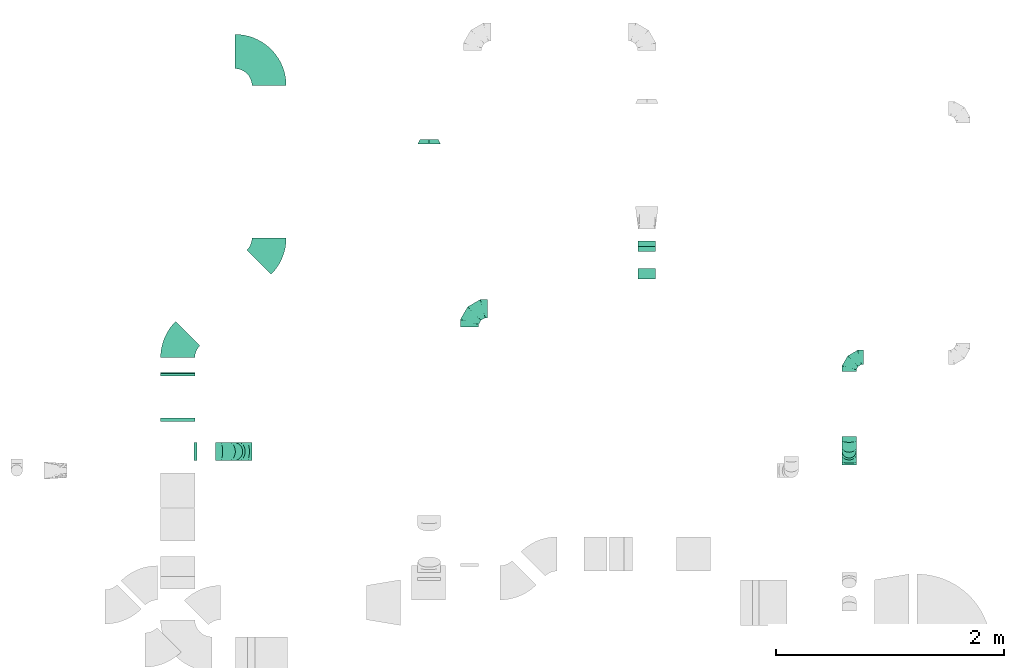
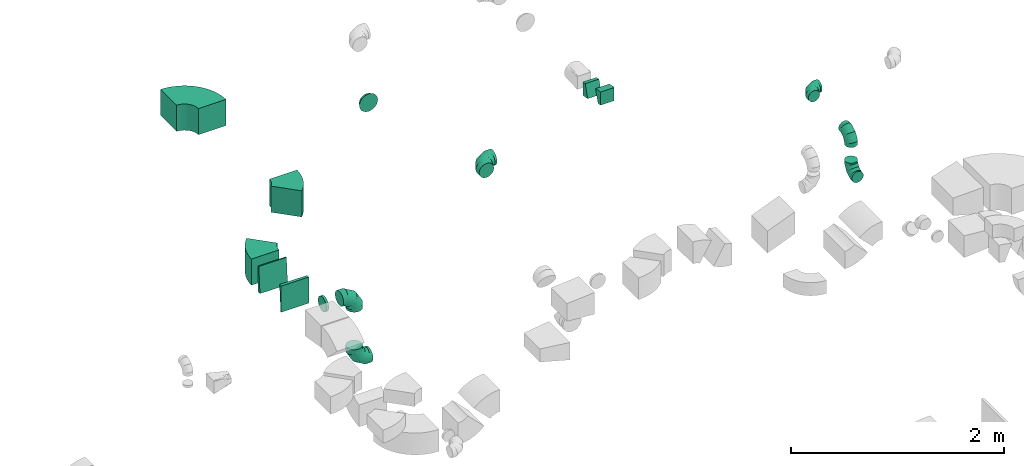
# One storey, part 33 of 44: 15 flow fittings.
"""IFC2X3 building model written with IfcOpenShell, lengths in millimetres."""

import ifcopenshell
import ifcopenshell.guid

model = None  # the IFC model being written
_history = None  # IfcOwnerHistory: only IFC2X3 demands one
_inside = {}  # id of a spatial element -> (the spatial element, [elements in it])
_under = {}  # id of a project, library or spatial element -> (it, [spatial elements below it])
_declared = {}  # id of a project -> (the project, [libraries it declares])
_typed = {}  # id of a type object -> (the type object, [elements of that type])
_made_of = {}  # id of a material, layer set ... -> (it, [elements and type objects made of it])


def new_model(schema):
    """Start an empty IFC model of exactly this schema.

    Asked for "IFC4X3", IfcOpenShell would pick the latest addendum, in which some entities
    have other attributes; the version numbers below select the first issue.
    IFC2X3 requires an IfcOwnerHistory on every rooted entity: one is made here for all.
    """
    global model, _history
    if schema == "IFC4X3":
        model = ifcopenshell.file(schema_version=(4, 3, 0, 0))
    else:
        model = ifcopenshell.file(schema=schema)
    _inside.clear()
    _under.clear()
    _declared.clear()
    _typed.clear()
    _made_of.clear()
    _history = None
    if model.schema == "IFC2X3":
        org = make("IfcOrganization", Name="unknown")
        user = make(
            "IfcPersonAndOrganization",
            ThePerson=make("IfcPerson", FamilyName="unknown"),
            TheOrganization=org,
        )
        app = make(
            "IfcApplication",
            ApplicationDeveloper=org,
            Version="unknown",
            ApplicationFullName="unknown",
            ApplicationIdentifier="unknown",
        )
        _history = make(
            "IfcOwnerHistory",
            OwningUser=user,
            OwningApplication=app,
            ChangeAction="ADDED",
            CreationDate=0,
        )
    return model


def make(cls, **values):
    """One entity of the class cls with the attributes given. An attribute that is None is left unset."""
    return model.create_entity(
        cls, **{name: value for name, value in values.items() if value is not None}
    )


def entity(cls, *values):
    """Any entity or typed value of the class cls, its attributes in the order of the schema. None: left unset."""
    e = model.create_entity(cls)
    for i, value in enumerate(values):
        if value is not None:
            e[i] = value
    return e


def rooted(cls, **values):
    """An entity with a GlobalId (a new one), such as an element, a storey or a relation."""
    return make(cls, GlobalId=ifcopenshell.guid.new(), OwnerHistory=_history, **values)


def si_unit(unit_type, name, prefix=None):
    """IfcSIUnit, for example si_unit("LENGTHUNIT", "METRE", prefix="MILLI")."""
    return make("IfcSIUnit", UnitType=unit_type, Prefix=prefix, Name=name)


def converted_unit(unit_type, name, factor, base, dimensions=None, offset=None):
    """IfcConversionBasedUnit, such as the inch: factor (a typed value) times the base unit."""
    return make(
        "IfcConversionBasedUnit"
        if offset is None
        else "IfcConversionBasedUnitWithOffset",
        ConversionOffset=offset,
        Dimensions=None
        if dimensions is None
        else entity("IfcDimensionalExponents", *dimensions),
        UnitType=unit_type,
        Name=name,
        ConversionFactor=make(
            "IfcMeasureWithUnit", ValueComponent=factor, UnitComponent=base
        ),
    )


def derived_unit(unit_type, elements):
    """IfcDerivedUnit: a product of units, each with its exponent."""
    return make(
        "IfcDerivedUnit",
        Elements=[
            make("IfcDerivedUnitElement", Unit=unit, Exponent=power)
            for unit, power in elements
        ],
        UnitType=unit_type,
    )


def assignment(units):
    """IfcUnitAssignment: the units of a project."""
    return None if units is None else make("IfcUnitAssignment", Units=units)


def point(xyz):
    """IfcCartesianPoint."""
    return None if xyz is None else make("IfcCartesianPoint", Coordinates=xyz)


def direction(xyz):
    """IfcDirection."""
    return None if xyz is None else make("IfcDirection", DirectionRatios=xyz)


def frame(location, z_axis=None, x_axis=None):
    """IfcAxis2Placement3D, a coordinate frame: its origin and axes. An axis left out is left unset."""
    return make(
        "IfcAxis2Placement3D",
        Location=point(location),
        Axis=direction(z_axis),
        RefDirection=direction(x_axis),
    )


def frame_2d(location, x_axis=None):
    """IfcAxis2Placement2D, a coordinate frame in the plane: its origin and x axis."""
    return make(
        "IfcAxis2Placement2D", Location=point(location), RefDirection=direction(x_axis)
    )


def origin():
    """The frame at (0, 0, 0) with its axes left unset."""
    return frame((0.0, 0.0, 0.0))


def place(relative_to, where):
    """IfcLocalPlacement: puts the frame where relative to a parent placement (None: the world)."""
    return make(
        "IfcLocalPlacement", PlacementRelTo=relative_to, RelativePlacement=where
    )


def context(
    kind, dimensions, precision=None, world=None, true_north=None, identifier=None
):
    """IfcGeometricRepresentationContext, for example the 3D "Model" context."""
    return make(
        "IfcGeometricRepresentationContext",
        ContextIdentifier=identifier,
        ContextType=kind,
        CoordinateSpaceDimension=dimensions,
        Precision=precision,
        WorldCoordinateSystem=world,
        TrueNorth=true_north,
    )


def subcontext(parent, identifier, kind, view, scale=None):
    """IfcGeometricRepresentationSubContext, for example "Body" below "Model"."""
    return make(
        "IfcGeometricRepresentationSubContext",
        ContextIdentifier=identifier,
        ContextType=kind,
        ParentContext=parent,
        TargetScale=scale,
        TargetView=view,
    )


def project(units=None, contexts=None):
    """IfcProject with its units and contexts."""
    return rooted(
        "IfcProject",
        Name="project",
        RepresentationContexts=contexts,
        UnitsInContext=assignment(units),
    )


def spatial(cls, under=None, at=None, **own):
    """A site, building, storey or space (cls), placed at a placement, below another one or the project."""
    s = rooted(cls, ObjectPlacement=at, **own)
    if under is not None:
        _under.setdefault(under.id(), (under, []))[1].append(s)
    return s


def polyline(points):
    """IfcPolyline through the points."""
    return make("IfcPolyline", Points=[point(p) for p in points])


def circle_curve(where, radius):
    """IfcCircle in the frame where."""
    return make("IfcCircle", Position=where, Radius=radius)


def parameter(value):
    """IfcParameterValue: where a trimmed curve begins or ends, as a parameter of its basis curve."""
    return model.create_entity("IfcParameterValue", value)


def trimmed(basis, trim1, trim2, sense, master):
    """IfcTrimmedCurve: the piece of a basis curve between two trims."""
    return make(
        "IfcTrimmedCurve",
        BasisCurve=basis,
        Trim1=trim1,
        Trim2=trim2,
        SenseAgreement=sense,
        MasterRepresentation=master,
    )


def segment(curve, same_sense, transition):
    """IfcCompositeCurveSegment."""
    return make(
        "IfcCompositeCurveSegment",
        Transition=transition,
        SameSense=same_sense,
        ParentCurve=curve,
    )


def composite_curve(segments, self_intersect=None):
    """IfcCompositeCurve: segments joined end to end."""
    return make("IfcCompositeCurve", Segments=segments, SelfIntersect=self_intersect)


def outline(outer, holes=None, kind="AREA"):
    """IfcArbitraryClosedProfileDef: a profile drawn as a closed curve; with holes, ...WithVoids."""
    if holes is None:
        return make("IfcArbitraryClosedProfileDef", ProfileType=kind, OuterCurve=outer)
    return make(
        "IfcArbitraryProfileDefWithVoids",
        ProfileType=kind,
        OuterCurve=outer,
        InnerCurves=holes,
    )


def extrude(swept, where, along, depth):
    """IfcExtrudedAreaSolid: the profile swept, set in the frame where, extruded along a direction by depth."""
    return make(
        "IfcExtrudedAreaSolid",
        SweptArea=swept,
        Position=where,
        ExtrudedDirection=direction(along),
        Depth=depth,
    )


def faces_of(points, faces, orient=None, outer=None):
    """IfcFace entities. A face is a list of loops; a loop is a list of indices into points, from 0.

    orient and outer hold one flag for each loop. By default every Orientation is true, the
    first loop of a face is its IfcFaceOuterBound and the others are IfcFaceBound.
    """
    made = []
    for i, loops in enumerate(faces):
        bounds = []
        for j, loop in enumerate(loops):
            is_outer = j == 0 if outer is None else outer[i][j]
            bounds.append(
                make(
                    "IfcFaceOuterBound" if is_outer else "IfcFaceBound",
                    Bound=make("IfcPolyLoop", Polygon=[points[k] for k in loop]),
                    Orientation=True if orient is None else orient[i][j],
                )
            )
        made.append(make("IfcFace", Bounds=bounds))
    return made


def faceted_brep(points, faces, orient=None, outer=None, voids=None):
    """IfcFacetedBrep: a solid bounded by flat faces; with voids (closed shells), ...WithVoids."""
    shared = [point(p) for p in points]
    hull = make("IfcClosedShell", CfsFaces=faces_of(shared, faces, orient, outer))
    if voids is None:
        return make("IfcFacetedBrep", Outer=hull)
    return make(
        "IfcFacetedBrepWithVoids",
        Outer=hull,
        Voids=[
            make(cls, CfsFaces=faces_of(shared, fs, o, b)) for cls, fs, o, b in voids
        ],
    )


def shape(context_of_items, identifier, shape_type, items):
    """IfcShapeRepresentation: the items that make up one representation, for example the "Body"."""
    return make(
        "IfcShapeRepresentation",
        ContextOfItems=context_of_items,
        RepresentationIdentifier=identifier,
        RepresentationType=shape_type,
        Items=items,
    )


def source(mapping_origin, context_of_items, identifier, shape_type, items):
    """IfcRepresentationMap: a shape defined once, which mapped items show again and again."""
    return make(
        "IfcRepresentationMap",
        MappingOrigin=mapping_origin,
        MappedRepresentation=shape(context_of_items, identifier, shape_type, items),
    )


def transform(
    local_origin,
    x_axis=None,
    y_axis=None,
    z_axis=None,
    scale=None,
    scale2=None,
    scale3=None,
    uniform=True,
):
    """IfcCartesianTransformationOperator3D, or its non-uniform kind. x_axis, y_axis, z_axis: its Axis1, 2, 3."""
    if uniform:
        return make(
            "IfcCartesianTransformationOperator3D",
            Axis1=direction(x_axis),
            Axis2=direction(y_axis),
            LocalOrigin=point(local_origin),
            Scale=scale,
            Axis3=direction(z_axis),
        )
    return make(
        "IfcCartesianTransformationOperator3DnonUniform",
        Axis1=direction(x_axis),
        Axis2=direction(y_axis),
        LocalOrigin=point(local_origin),
        Scale=scale,
        Axis3=direction(z_axis),
        Scale2=scale2,
        Scale3=scale3,
    )


def mapped(mapping_source, mapping_target):
    """IfcMappedItem: shows the shape of a source again, moved by a transform."""
    return make(
        "IfcMappedItem", MappingSource=mapping_source, MappingTarget=mapping_target
    )


def material(Name=None, Category=None):
    """IfcMaterial."""
    return make("IfcMaterial", Name=Name, Category=Category)


def made_of(thing, what):
    """Note that an element or type object is made of a material, layer set ...; save() writes the relation."""
    if what is not None:
        _made_of.setdefault(what.id(), (what, []))[1].append(thing)
    return thing


def type_object(cls, material=None, **own):
    """A type object (cls), such as IfcWallType, which elements share."""
    return made_of(rooted(cls, **own), material)


def type_shapes(of_type, sources):
    """Give a type object the sources (RepresentationMaps) that its elements show as mapped items."""
    of_type.RepresentationMaps = sources


def element(
    cls,
    number,
    at=None,
    inside=None,
    cuts=None,
    type_object=None,
    material=None,
    context=None,
    identifier="Body",
    shape_type=None,
    held_by="IfcProductDefinitionShape",
    body=None,
    shapes=None,
    **own,
):
    """One element of the class cls, such as IfcWall. Its Tag is "e" and its number.

    at: its placement. inside: the storey or other place that contains it. cuts: it is an
    opening in that element (IfcRelVoidsElement). A single representation is given by context,
    identifier, shape_type and body (its items); several are given by shapes. held_by: the class
    of the entity that holds the representations. save() writes the other relations.
    """
    e = rooted(cls, Tag="e%d" % number, ObjectPlacement=at, **own)
    if body is not None:
        shapes = [shape(context, identifier, shape_type, body)]
    if shapes is not None:
        e.Representation = make(held_by, Representations=shapes)
    if inside is not None:
        _inside.setdefault(inside.id(), (inside, []))[1].append(e)
    if cuts is not None:
        rooted(
            "IfcRelVoidsElement", RelatingBuildingElement=cuts, RelatedOpeningElement=e
        )
    if type_object is not None:
        _typed.setdefault(type_object.id(), (type_object, []))[1].append(e)
    return made_of(e, material)


def aggregate(whole, parts):
    """IfcRelAggregates: a whole, such as a stair, and the parts it consists of."""
    return rooted("IfcRelAggregates", RelatingObject=whole, RelatedObjects=parts)


def save(model, path):
    """Write the relations noted so far, then the file.

    IfcRelAggregates (storeys below a building ...), IfcRelContainedInSpatialStructure (elements
    in a storey), IfcRelDefinesByType, IfcRelAssociatesMaterial and IfcRelDeclares: one each for
    every whole, place, type object, material and project.
    """
    for whole, parts in _under.values():
        aggregate(whole, parts)
    for where, things in _inside.values():
        rooted(
            "IfcRelContainedInSpatialStructure",
            RelatedElements=things,
            RelatingStructure=where,
        )
    for kind, things in _typed.values():
        rooted("IfcRelDefinesByType", RelatedObjects=things, RelatingType=kind)
    for what, things in _made_of.values():
        rooted("IfcRelAssociatesMaterial", RelatedObjects=things, RelatingMaterial=what)
    for by, libraries in _declared.values():
        rooted("IfcRelDeclares", RelatingContext=by, RelatedDefinitions=libraries)
    model.write(path)


model = new_model("IFC2X3")

# Units and contexts
model_context = context("Model", 3, precision=0.01, world=origin(), true_north=direction((6.12303176911189e-17, 1.0)))
body_context = subcontext(model_context, "Body", "Model", "MODEL_VIEW")
ifc_project = project(units=[si_unit("LENGTHUNIT", "METRE", prefix="MILLI"), si_unit("AREAUNIT", "SQUARE_METRE"), si_unit("VOLUMEUNIT", "CUBIC_METRE"), converted_unit("PLANEANGLEUNIT", "DEGREE", entity("IfcRatioMeasure", 0.0174532925199433), si_unit("PLANEANGLEUNIT", "RADIAN"), dimensions=[0, 0, 0, 0, 0, 0, 0]), si_unit("MASSUNIT", "GRAM", prefix="KILO"), derived_unit("MASSDENSITYUNIT", [(si_unit("MASSUNIT", "GRAM", prefix="KILO"), 1), (si_unit("LENGTHUNIT", "METRE"), -3)]), derived_unit("MOMENTOFINERTIAUNIT", [(si_unit("LENGTHUNIT", "METRE"), 4)]), si_unit("TIMEUNIT", "SECOND"), si_unit("FREQUENCYUNIT", "HERTZ"), si_unit("THERMODYNAMICTEMPERATUREUNIT", "DEGREE_CELSIUS"), derived_unit("THERMALTRANSMITTANCEUNIT", [(si_unit("MASSUNIT", "GRAM", prefix="KILO"), 1), (si_unit("THERMODYNAMICTEMPERATUREUNIT", "KELVIN"), -1), (si_unit("TIMEUNIT", "SECOND"), -3)]), derived_unit("VOLUMETRICFLOWRATEUNIT", [(si_unit("LENGTHUNIT", "METRE"), 3), (si_unit("TIMEUNIT", "SECOND"), -1)]), derived_unit("MASSFLOWRATEUNIT", [(si_unit("MASSUNIT", "GRAM", prefix="KILO"), 1), (si_unit("TIMEUNIT", "SECOND"), -1)]), derived_unit("ROTATIONALFREQUENCYUNIT", [(si_unit("TIMEUNIT", "SECOND"), -1)]), si_unit("ELECTRICCURRENTUNIT", "AMPERE"), si_unit("ELECTRICVOLTAGEUNIT", "VOLT"), si_unit("POWERUNIT", "WATT"), si_unit("FORCEUNIT", "NEWTON", prefix="KILO"), si_unit("ILLUMINANCEUNIT", "LUX"), si_unit("LUMINOUSFLUXUNIT", "LUMEN"), si_unit("LUMINOUSINTENSITYUNIT", "CANDELA"), derived_unit("USERDEFINED", [(si_unit("MASSUNIT", "GRAM", prefix="KILO"), -1), (si_unit("LENGTHUNIT", "METRE"), -2), (si_unit("TIMEUNIT", "SECOND"), 3), (si_unit("LUMINOUSFLUXUNIT", "LUMEN"), 1)]), derived_unit("LINEARVELOCITYUNIT", [(si_unit("LENGTHUNIT", "METRE"), 1), (si_unit("TIMEUNIT", "SECOND"), -1)]), si_unit("PRESSUREUNIT", "PASCAL"), derived_unit("USERDEFINED", [(si_unit("LENGTHUNIT", "METRE"), -2), (si_unit("MASSUNIT", "GRAM", prefix="KILO"), 1), (si_unit("TIMEUNIT", "SECOND"), -2)]), derived_unit("LINEARFORCEUNIT", [(si_unit("MASSUNIT", "GRAM", prefix="KILO"), 1), (si_unit("LENGTHUNIT", "METRE"), 1), (si_unit("TIMEUNIT", "SECOND"), -2), (si_unit("LENGTHUNIT", "METRE"), -1)]), derived_unit("PLANARFORCEUNIT", [(si_unit("MASSUNIT", "GRAM", prefix="KILO"), 1), (si_unit("LENGTHUNIT", "METRE"), 1), (si_unit("TIMEUNIT", "SECOND"), -2), (si_unit("LENGTHUNIT", "METRE"), -2)])], contexts=[model_context])

# Site, building, storey
site_placement = place(None, origin())
site = spatial("IfcSite", under=ifc_project, at=site_placement, CompositionType="ELEMENT")
building_placement = place(site_placement, origin())
building = spatial("IfcBuilding", under=site, at=building_placement, CompositionType="ELEMENT")
storey_placement = place(building_placement, frame((0.0, 0.0, 15900.0)))
storey = spatial("IfcBuildingStorey", under=building, at=storey_placement, CompositionType="ELEMENT", Elevation=15900.0)

# Flow fittings
ifc_material = material()
duct_fitting_type_1 = type_object("IfcDuctFittingType", PredefinedType="NOTDEFINED", material=ifc_material)
shared_shape_1 = source(origin(), body_context, "Body", "Brep", [
    faceted_brep([(-160.0, 0.0, -80.0), (-160.0, -20.71, -77.27), (-160.0, -40.0, -69.28), (-160.0, -56.57, -56.57), (-160.0, -69.28, -40.0), (-160.0, -77.27, -20.71), (-160.0, -80.0, 0.0), (-160.0, -77.27, 20.71), (-160.0, -69.28, 40.0), (-160.0, -56.57, 56.57), (-160.0, -40.0, 69.28), (-160.0, -20.71, 77.27), (-160.0, 0.0, 80.0), (-160.0, 20.71, 77.27), (-160.0, 40.0, 69.28), (-160.0, 56.57, 56.57), (-160.0, 69.28, 40.0), (-160.0, 77.27, 20.71), (-160.0, 80.0, 0.0), (-160.0, 77.27, -20.71), (-160.0, 69.28, -40.0), (-160.0, 56.57, -56.57), (-160.0, 40.0, -69.28), (-160.0, 20.71, -77.27), (-122.68, 20.71, 77.27), (-127.85, 40.0, 69.28), (-117.13, 0.0, 80.0), (-132.29, 56.57, 56.57), (-137.83, 77.27, 20.71), (-138.56, 80.0, 0.0), (-135.69, 69.28, 40.0), (-135.69, 69.28, -40.0), (-132.29, 56.57, -56.57), (-137.83, 77.27, -20.71), (-122.68, 20.71, -77.27), (-117.13, 0.0, -80.0), (-127.85, 40.0, -69.28), (-111.58, -20.71, -77.27), (-106.41, -40.0, -69.28), (-101.97, -56.57, -56.57), (-98.56, -69.28, -40.0), (-96.42, -77.27, -20.71), (-95.69, -80.0, 0.0), (-96.42, -77.27, 20.71), (-98.56, -69.28, 40.0), (-101.97, -56.57, 56.57), (-106.41, -40.0, 69.28), (-111.58, -20.71, 77.27), (-58.03, 58.03, 77.27), (-72.15, 72.15, 69.28), (-42.87, 42.87, 80.0), (-84.28, 84.28, 56.57), (-93.59, 93.59, 40.0), (-99.44, 99.44, 20.71), (-101.44, 101.44, 0.0), (-99.44, 99.44, -20.71), (-93.59, 93.59, -40.0), (-84.28, 84.28, -56.57), (-58.03, 58.03, -77.27), (-42.87, 42.87, -80.0), (-72.15, 72.15, -69.28), (-27.71, 27.71, -77.27), (-13.59, 13.59, -69.28), (-1.46, 1.46, -56.57), (7.85, -7.85, -40.0), (13.7, -13.7, -20.71), (15.69, -15.69, 0.0), (13.7, -13.7, 20.71), (7.85, -7.85, 40.0), (-1.46, 1.46, 56.57), (-13.59, 13.59, 69.28), (-27.71, 27.71, 77.27), (-20.71, 122.68, 77.27), (-40.0, 127.85, 69.28), (0.0, 117.13, 80.0), (-56.57, 132.29, 56.57), (-69.28, 135.69, 40.0), (-77.27, 137.83, 20.71), (-80.0, 138.56, 0.0), (-77.27, 137.83, -20.71), (-69.28, 135.69, -40.0), (-56.57, 132.29, -56.57), (-20.71, 122.68, -77.27), (0.0, 117.13, -80.0), (-40.0, 127.85, -69.28), (20.71, 111.58, -77.27), (40.0, 106.41, -69.28), (56.57, 101.97, -56.57), (69.28, 98.56, -40.0), (77.27, 96.42, -20.71), (80.0, 95.69, 0.0), (77.27, 96.42, 20.71), (69.28, 98.56, 40.0), (56.57, 101.97, 56.57), (40.0, 106.41, 69.28), (20.71, 111.58, 77.27), (-20.71, 160.0, -77.27), (-40.0, 160.0, -69.28), (-56.57, 160.0, -56.57), (-69.28, 160.0, -40.0), (-77.27, 160.0, -20.71), (-80.0, 160.0, 0.0), (-77.27, 160.0, 20.71), (-69.28, 160.0, 40.0), (-56.57, 160.0, 56.57), (-40.0, 160.0, 69.28), (-20.71, 160.0, 77.27), (0.0, 160.0, 80.0), (20.71, 160.0, 77.27), (40.0, 160.0, 69.28), (56.57, 160.0, 56.57), (69.28, 160.0, 40.0), (77.27, 160.0, 20.71), (80.0, 160.0, 0.0), (77.27, 160.0, -20.71), (69.28, 160.0, -40.0), (56.57, 160.0, -56.57), (40.0, 160.0, -69.28), (20.71, 160.0, -77.27), (0.0, 160.0, -80.0)], [[[0, 1, 2, 3, 4, 5, 6, 7, 8, 9, 10, 11, 12, 13, 14, 15, 16, 17, 18, 19, 20, 21, 22, 23]], [[24, 25, 14, 13]], [[26, 24, 13, 12]], [[14, 25, 27, 15]], [[28, 29, 18, 17]], [[30, 28, 17, 16]], [[15, 27, 30, 16]], [[20, 31, 32, 21]], [[33, 31, 20, 19]], [[18, 29, 33, 19]], [[34, 35, 0, 23]], [[36, 34, 23, 22]], [[32, 36, 22, 21]], [[1, 0, 35, 37]], [[2, 1, 37, 38]], [[3, 2, 38, 39]], [[5, 4, 40, 41]], [[6, 5, 41, 42]], [[39, 40, 4, 3]], [[6, 42, 43, 7]], [[7, 43, 44, 8]], [[8, 44, 45, 9]], [[9, 45, 46, 10]], [[10, 46, 47, 11]], [[26, 12, 11, 47]], [[48, 49, 25, 24]], [[50, 48, 24, 26]], [[27, 25, 49, 51]], [[52, 53, 28, 30]], [[51, 52, 30, 27]], [[29, 28, 53, 54]], [[55, 56, 31, 33]], [[54, 55, 33, 29]], [[32, 31, 56, 57]], [[58, 59, 35, 34]], [[60, 58, 34, 36]], [[57, 60, 36, 32]], [[37, 35, 59, 61]], [[38, 37, 61, 62]], [[39, 38, 62, 63]], [[41, 40, 64, 65]], [[42, 41, 65, 66]], [[63, 64, 40, 39]], [[43, 42, 66, 67]], [[44, 43, 67, 68]], [[68, 69, 45, 44]], [[46, 45, 69, 70]], [[47, 46, 70, 71]], [[26, 47, 71, 50]], [[72, 73, 49, 48]], [[74, 72, 48, 50]], [[51, 49, 73, 75]], [[76, 77, 53, 52]], [[75, 76, 52, 51]], [[54, 53, 77, 78]], [[79, 80, 56, 55]], [[78, 79, 55, 54]], [[57, 56, 80, 81]], [[82, 83, 59, 58]], [[84, 82, 58, 60]], [[81, 84, 60, 57]], [[61, 59, 83, 85]], [[62, 61, 85, 86]], [[63, 62, 86, 87]], [[65, 64, 88, 89]], [[66, 65, 89, 90]], [[87, 88, 64, 63]], [[67, 66, 90, 91]], [[68, 67, 91, 92]], [[92, 93, 69, 68]], [[70, 69, 93, 94]], [[71, 70, 94, 95]], [[50, 71, 95, 74]], [[96, 97, 98, 99, 100, 101, 102, 103, 104, 105, 106, 107, 108, 109, 110, 111, 112, 113, 114, 115, 116, 117, 118, 119]], [[72, 74, 107, 106]], [[73, 72, 106, 105]], [[75, 73, 105, 104]], [[77, 76, 103, 102]], [[78, 77, 102, 101]], [[75, 104, 103, 76]], [[78, 101, 100, 79]], [[79, 100, 99, 80]], [[80, 99, 98, 81]], [[84, 97, 96, 82]], [[82, 96, 119, 83]], [[84, 81, 98, 97]], [[118, 117, 86, 85]], [[119, 118, 85, 83]], [[116, 87, 86, 117]], [[88, 115, 114, 89]], [[89, 114, 113, 90]], [[115, 88, 87, 116]], [[112, 111, 92, 91]], [[113, 112, 91, 90]], [[111, 110, 93, 92]], [[95, 94, 109, 108]], [[74, 95, 108, 107]], [[110, 109, 94, 93]]]),
])
type_shapes(duct_fitting_type_1, [shared_shape_1])
for number, where, z_axis, x_axis in (
    (1, (47258.09, 16297.84, 2550.0), (0.0, 1.0, 0.0), (-1.0, 0.0, 0.0)),
    (2, (49322.84, 17549.06, 3325.0), (0.0, 0.0, 1.0), (-1.0, 0.0, 0.0)),
    (3, (47258.09, 16297.84, 3300.0), (0.0, -1.0, 0.0), (0.0, 0.0, 1.0)),
):
    element("IfcFlowFitting", number, at=place(storey_placement, frame(where, z_axis=z_axis, x_axis=x_axis)), inside=storey, type_object=duct_fitting_type_1, material=ifc_material, context=body_context, shape_type="MappedRepresentation", body=[
        mapped(shared_shape_1, transform((0.0, 0.0, 0.0), scale=1.0)),
    ])
duct_fitting_type_2 = type_object("IfcDuctFittingType", PredefinedType="NOTDEFINED", material=ifc_material)
shared_shape_2 = source(origin(), body_context, "Body", "Brep", [
    faceted_brep([(-125.0, 0.0, -62.5), (-125.0, -16.18, -60.37), (-125.0, -31.25, -54.13), (-125.0, -44.19, -44.19), (-125.0, -54.13, -31.25), (-125.0, -60.37, -16.18), (-125.0, -62.5, 0.0), (-125.0, -60.37, 16.18), (-125.0, -54.13, 31.25), (-125.0, -44.19, 44.19), (-125.0, -31.25, 54.13), (-125.0, -16.18, 60.37), (-125.0, 0.0, 62.5), (-125.0, 16.18, 60.37), (-125.0, 31.25, 54.13), (-125.0, 44.19, 44.19), (-125.0, 54.13, 31.25), (-125.0, 60.37, 16.18), (-125.0, 62.5, 0.0), (-125.0, 60.37, -16.18), (-125.0, 54.13, -31.25), (-125.0, 44.19, -44.19), (-125.0, 31.25, -54.13), (-125.0, 16.18, -60.37), (-95.84, 16.18, 60.37), (-99.88, 31.25, 54.13), (-91.51, 0.0, 62.5), (-103.35, 44.19, 44.19), (-107.68, 60.37, 16.18), (-108.25, 62.5, 0.0), (-106.01, 54.13, 31.25), (-106.01, 54.13, -31.25), (-103.35, 44.19, -44.19), (-107.68, 60.37, -16.18), (-95.84, 16.18, -60.37), (-91.51, 0.0, -62.5), (-99.88, 31.25, -54.13), (-87.17, -16.18, -60.37), (-83.13, -31.25, -54.13), (-79.66, -44.19, -44.19), (-77.0, -54.13, -31.25), (-75.33, -60.37, -16.18), (-74.76, -62.5, 0.0), (-75.33, -60.37, 16.18), (-77.0, -54.13, 31.25), (-79.66, -44.19, 44.19), (-83.13, -31.25, 54.13), (-87.17, -16.18, 60.37), (-45.34, 45.34, 60.37), (-56.37, 56.37, 54.13), (-33.49, 33.49, 62.5), (-65.85, 65.85, 44.19), (-73.12, 73.12, 31.25), (-77.69, 77.69, 16.18), (-79.25, 79.25, 0.0), (-77.69, 77.69, -16.18), (-73.12, 73.12, -31.25), (-65.85, 65.85, -44.19), (-45.34, 45.34, -60.37), (-33.49, 33.49, -62.5), (-56.37, 56.37, -54.13), (-21.65, 21.65, -60.37), (-10.62, 10.62, -54.13), (-1.14, 1.14, -44.19), (6.13, -6.13, -31.25), (10.7, -10.7, -16.18), (12.26, -12.26, 0.0), (10.7, -10.7, 16.18), (6.13, -6.13, 31.25), (-1.14, 1.14, 44.19), (-10.62, 10.62, 54.13), (-21.65, 21.65, 60.37), (-16.18, 95.84, 60.37), (-31.25, 99.88, 54.13), (0.0, 91.51, 62.5), (-44.19, 103.35, 44.19), (-54.13, 106.01, 31.25), (-60.37, 107.68, 16.18), (-62.5, 108.25, 0.0), (-60.37, 107.68, -16.18), (-54.13, 106.01, -31.25), (-44.19, 103.35, -44.19), (-16.18, 95.84, -60.37), (0.0, 91.51, -62.5), (-31.25, 99.88, -54.13), (16.18, 87.17, -60.37), (31.25, 83.13, -54.13), (44.19, 79.66, -44.19), (54.13, 77.0, -31.25), (60.37, 75.33, -16.18), (62.5, 74.76, 0.0), (60.37, 75.33, 16.18), (54.13, 77.0, 31.25), (44.19, 79.66, 44.19), (31.25, 83.13, 54.13), (16.18, 87.17, 60.37), (-16.18, 125.0, -60.37), (-31.25, 125.0, -54.13), (-44.19, 125.0, -44.19), (-54.13, 125.0, -31.25), (-60.37, 125.0, -16.18), (-62.5, 125.0, 0.0), (-60.37, 125.0, 16.18), (-54.13, 125.0, 31.25), (-44.19, 125.0, 44.19), (-31.25, 125.0, 54.13), (-16.18, 125.0, 60.37), (0.0, 125.0, 62.5), (16.18, 125.0, 60.37), (31.25, 125.0, 54.13), (44.19, 125.0, 44.19), (54.13, 125.0, 31.25), (60.37, 125.0, 16.18), (62.5, 125.0, 0.0), (60.37, 125.0, -16.18), (54.13, 125.0, -31.25), (44.19, 125.0, -44.19), (31.25, 125.0, -54.13), (16.18, 125.0, -60.37), (0.0, 125.0, -62.5)], [[[0, 1, 2, 3, 4, 5, 6, 7, 8, 9, 10, 11, 12, 13, 14, 15, 16, 17, 18, 19, 20, 21, 22, 23]], [[24, 25, 14, 13]], [[26, 24, 13, 12]], [[14, 25, 27, 15]], [[28, 29, 18, 17]], [[30, 28, 17, 16]], [[15, 27, 30, 16]], [[20, 31, 32, 21]], [[33, 31, 20, 19]], [[18, 29, 33, 19]], [[34, 35, 0, 23]], [[36, 34, 23, 22]], [[21, 32, 36, 22]], [[1, 0, 35, 37]], [[2, 1, 37, 38]], [[38, 39, 3, 2]], [[5, 4, 40, 41]], [[6, 5, 41, 42]], [[39, 40, 4, 3]], [[6, 42, 43, 7]], [[7, 43, 44, 8]], [[45, 9, 8, 44]], [[9, 45, 46, 10]], [[10, 46, 47, 11]], [[26, 12, 11, 47]], [[48, 49, 25, 24]], [[50, 48, 24, 26]], [[27, 25, 49, 51]], [[52, 53, 28, 30]], [[51, 52, 30, 27]], [[29, 28, 53, 54]], [[55, 56, 31, 33]], [[54, 55, 33, 29]], [[57, 32, 31, 56]], [[58, 59, 35, 34]], [[60, 58, 34, 36]], [[57, 60, 36, 32]], [[37, 35, 59, 61]], [[38, 37, 61, 62]], [[39, 38, 62, 63]], [[41, 40, 64, 65]], [[42, 41, 65, 66]], [[63, 64, 40, 39]], [[43, 42, 66, 67]], [[44, 43, 67, 68]], [[68, 69, 45, 44]], [[46, 45, 69, 70]], [[47, 46, 70, 71]], [[26, 47, 71, 50]], [[72, 73, 49, 48]], [[74, 72, 48, 50]], [[51, 49, 73, 75]], [[76, 77, 53, 52]], [[75, 76, 52, 51]], [[54, 53, 77, 78]], [[79, 80, 56, 55]], [[78, 79, 55, 54]], [[81, 57, 56, 80]], [[82, 83, 59, 58]], [[84, 82, 58, 60]], [[81, 84, 60, 57]], [[61, 59, 83, 85]], [[62, 61, 85, 86]], [[63, 62, 86, 87]], [[65, 64, 88, 89]], [[66, 65, 89, 90]], [[87, 88, 64, 63]], [[67, 66, 90, 91]], [[68, 67, 91, 92]], [[92, 93, 69, 68]], [[70, 69, 93, 94]], [[71, 70, 94, 95]], [[50, 71, 95, 74]], [[96, 97, 98, 99, 100, 101, 102, 103, 104, 105, 106, 107, 108, 109, 110, 111, 112, 113, 114, 115, 116, 117, 118, 119]], [[72, 74, 107, 106]], [[73, 72, 106, 105]], [[75, 73, 105, 104]], [[77, 76, 103, 102]], [[78, 77, 102, 101]], [[75, 104, 103, 76]], [[78, 101, 100, 79]], [[79, 100, 99, 80]], [[80, 99, 98, 81]], [[96, 119, 83, 82]], [[97, 96, 82, 84]], [[84, 81, 98, 97]], [[83, 119, 118, 85]], [[85, 118, 117, 86]], [[116, 87, 86, 117]], [[88, 115, 114, 89]], [[89, 114, 113, 90]], [[115, 88, 87, 116]], [[91, 90, 113, 112]], [[92, 91, 112, 111]], [[111, 110, 93, 92]], [[95, 94, 109, 108]], [[74, 95, 108, 107]], [[110, 109, 94, 93]]]),
])
type_shapes(duct_fitting_type_2, [shared_shape_2])
for number, where, z_axis, x_axis in (
    (4, (52646.56, 17122.82, 3250.0), (0.0, 0.0, 1.0), (-1.0, 0.0, 0.0)),
    (5, (52646.56, 16303.82, 3250.0), (1.0, 0.0, 0.0), (0.0, -1.0, 0.0)),
    (6, (52646.56, 16303.82, 2820.0), (-1.0, 0.0, 0.0), (0.0, 0.0, -1.0)),
):
    element("IfcFlowFitting", number, at=place(storey_placement, frame(where, z_axis=z_axis, x_axis=x_axis)), inside=storey, type_object=duct_fitting_type_2, material=ifc_material, context=body_context, shape_type="MappedRepresentation", body=[
        mapped(shared_shape_2, transform((0.0, 0.0, 0.0), scale=1.0)),
    ])
duct_fitting_type_3 = type_object("IfcDuctFittingType", PredefinedType="NOTDEFINED", material=ifc_material)
shared_shape_3 = source(origin(), body_context, "Body", "Brep", [
    faceted_brep([(20.0, 0.0, -80.0), (20.0, 20.71, -77.27), (20.0, 40.0, -69.28), (20.0, 56.57, -56.57), (20.0, 69.28, -40.0), (20.0, 77.27, -20.71), (20.0, 80.0, 0.0), (20.0, 77.27, 20.71), (20.0, 69.28, 40.0), (20.0, 56.57, 56.57), (20.0, 40.0, 69.28), (20.0, 20.71, 77.27), (20.0, 0.0, 80.0), (20.0, -20.71, 77.27), (20.0, -40.0, 69.28), (20.0, -56.57, 56.57), (20.0, -69.28, 40.0), (20.0, -77.27, 20.71), (20.0, -80.0, 0.0), (20.0, -77.27, -20.71), (20.0, -69.28, -40.0), (20.0, -56.57, -56.57), (20.0, -40.0, -69.28), (20.0, -20.71, -77.27), (0.0, 0.0, 80.0), (-6.1, 0.0, 80.0), (-6.1, -20.71, 77.27), (0.0, -20.71, 77.27), (-6.1, -40.0, 69.28), (0.0, -40.0, 69.28), (0.0, -56.57, 56.57), (-6.1, -56.57, 56.57), (0.0, -69.28, 40.0), (-6.1, -69.28, 40.0), (-6.1, -77.27, 20.71), (0.0, -77.27, 20.71), (-6.1, -80.0, 0.0), (0.0, -80.0, 0.0), (-6.1, -77.27, -20.71), (0.0, -77.27, -20.71), (-6.1, -69.28, -40.0), (0.0, -69.28, -40.0), (0.0, -56.57, -56.57), (-6.1, -56.57, -56.57), (0.0, -40.0, -69.28), (-6.1, -40.0, -69.28), (-6.1, -20.71, -77.27), (0.0, -20.71, -77.27), (-6.1, 0.0, -80.0), (0.0, 0.0, -80.0), (-6.1, 20.71, -77.27), (0.0, 20.71, -77.27), (-6.1, 40.0, -69.28), (0.0, 40.0, -69.28), (0.0, 56.57, -56.57), (-6.1, 56.57, -56.57), (0.0, 69.28, -40.0), (-6.1, 69.28, -40.0), (-6.1, 77.27, -20.71), (0.0, 77.27, -20.71), (-6.1, 80.0, 0.0), (0.0, 80.0, 0.0), (-6.1, 77.27, 20.71), (0.0, 77.27, 20.71), (-6.1, 69.28, 40.0), (0.0, 69.28, 40.0), (0.0, 56.57, 56.57), (-6.1, 56.57, 56.57), (0.0, 40.0, 69.28), (-6.1, 40.0, 69.28), (-6.1, 20.71, 77.27), (0.0, 20.71, 77.27)], [[[0, 1, 2, 3, 4, 5, 6, 7, 8, 9, 10, 11, 12, 13, 14, 15, 16, 17, 18, 19, 20, 21, 22, 23]], [[13, 12, 24, 25, 26, 27]], [[14, 13, 27, 26, 28, 29]], [[30, 15, 14, 29, 28, 31]], [[17, 16, 32, 33, 34, 35]], [[18, 17, 35, 34, 36, 37]], [[32, 16, 15, 30, 31, 33]], [[19, 18, 37, 36, 38, 39]], [[20, 19, 39, 38, 40, 41]], [[42, 21, 20, 41, 40, 43]], [[23, 22, 44, 45, 46, 47]], [[0, 23, 47, 46, 48, 49]], [[44, 22, 21, 42, 43, 45]], [[1, 0, 49, 48, 50, 51]], [[2, 1, 51, 50, 52, 53]], [[54, 3, 2, 53, 52, 55]], [[5, 4, 56, 57, 58, 59]], [[6, 5, 59, 58, 60, 61]], [[56, 4, 3, 54, 55, 57]], [[7, 6, 61, 60, 62, 63]], [[8, 7, 63, 62, 64, 65]], [[66, 9, 8, 65, 64, 67]], [[11, 10, 68, 69, 70, 71]], [[12, 11, 71, 70, 25, 24]], [[68, 10, 9, 66, 67, 69]], [[46, 45, 43, 40, 38, 36, 34, 33, 31, 28, 26, 25, 70, 69, 67, 64, 62, 60, 58, 57, 55, 52, 50, 48]]]),
])
type_shapes(duct_fitting_type_3, [shared_shape_3])
flow_fitting_1_placement = place(storey_placement, frame((46919.03, 16297.84, 3300.0), z_axis=(0.0, 0.0, -1.0), x_axis=(1.0, 0.0, 0.0)))
element("IfcFlowFitting", 7, at=flow_fitting_1_placement, inside=storey, type_object=duct_fitting_type_3, material=ifc_material, context=body_context, shape_type="MappedRepresentation", body=[
    mapped(shared_shape_3, transform((0.0, 0.0, 0.0), scale=1.0)),
])
duct_fitting_type_4 = type_object("IfcDuctFittingType", PredefinedType="NOTDEFINED", material=ifc_material)
shared_shape_4 = source(origin(), body_context, "Body", "Brep", [
    faceted_brep([(40.0, -73.91, 30.61), (40.0, -76.96, 15.31), (40.0, -80.0, 0.0), (40.0, -76.96, -15.31), (40.0, -73.91, -30.61), (40.0, -65.24, -43.59), (40.0, -56.57, -56.57), (40.0, -43.59, -65.24), (40.0, -30.61, -73.91), (40.0, -15.31, -76.96), (40.0, 0.0, -80.0), (40.0, 15.31, -76.96), (40.0, 30.61, -73.91), (40.0, 43.59, -65.24), (40.0, 56.57, -56.57), (40.0, 65.24, -43.59), (40.0, 73.91, -30.61), (40.0, 76.96, -15.31), (40.0, 80.0, 0.0), (40.0, 76.96, 15.31), (40.0, 73.91, 30.61), (40.0, 65.24, 43.59), (40.0, 56.57, 56.57), (40.0, 43.59, 65.24), (40.0, 30.61, 73.91), (40.0, 15.31, 76.96), (40.0, 0.0, 80.0), (40.0, -15.31, 76.96), (40.0, -30.61, 73.91), (40.0, -43.59, 65.24), (40.0, -56.57, 56.57), (40.0, -65.24, 43.59), (0.0, -100.0, 0.0), (0.0, -95.11, 30.9), (0.0, -80.9, 58.78), (0.0, -58.78, 80.9), (0.0, -30.9, 95.11), (0.0, 0.0, 100.0), (0.0, 30.9, 95.11), (0.0, 58.78, 80.9), (0.0, 80.9, 58.78), (0.0, 95.11, 30.9), (0.0, 100.0, 0.0), (0.0, 95.11, -30.9), (0.0, 80.9, -58.78), (0.0, 58.78, -80.9), (0.0, 30.9, -95.11), (0.0, 0.0, -100.0), (0.0, -30.9, -95.11), (0.0, -58.78, -80.9), (0.0, -80.9, -58.78), (0.0, -95.11, -30.9)], [[[0, 1, 2, 3, 4, 5, 6, 7, 8, 9, 10, 11, 12, 13, 14, 15, 16, 17, 18, 19, 20, 21, 22, 23, 24, 25, 26, 27, 28, 29, 30, 31]], [[32, 33, 34, 35, 36, 37, 38, 39, 40, 41, 42, 43, 44, 45, 46, 47, 48, 49, 50, 51]], [[37, 25, 38]], [[25, 24, 38]], [[24, 39, 38]], [[41, 20, 19]], [[25, 37, 26]], [[39, 24, 23, 22]], [[42, 19, 18]], [[20, 40, 22, 21]], [[41, 40, 20]], [[42, 41, 19]], [[22, 40, 39]], [[32, 1, 33]], [[1, 0, 33]], [[0, 34, 33]], [[36, 28, 27]], [[1, 32, 2]], [[34, 0, 31, 30]], [[37, 27, 26]], [[28, 35, 30, 29]], [[36, 35, 28]], [[37, 36, 27]], [[30, 35, 34]], [[47, 9, 48]], [[9, 8, 48]], [[8, 49, 48]], [[51, 4, 3]], [[9, 47, 10]], [[49, 8, 7, 6]], [[32, 3, 2]], [[4, 50, 6, 5]], [[51, 50, 4]], [[32, 51, 3]], [[6, 50, 49]], [[42, 17, 43]], [[17, 16, 43]], [[16, 44, 43]], [[46, 12, 11]], [[17, 42, 18]], [[44, 16, 15, 14]], [[47, 11, 10]], [[12, 45, 14, 13]], [[46, 45, 12]], [[47, 46, 11]], [[14, 45, 44]]]),
])
type_shapes(duct_fitting_type_4, [shared_shape_4])
flow_fitting_2_placement = place(storey_placement, frame((48969.75, 18990.52, 3255.0), z_axis=(0.0, 0.0, 1.0), x_axis=(0.0, 1.0, 0.0)))
element("IfcFlowFitting", 8, at=flow_fitting_2_placement, inside=storey, type_object=duct_fitting_type_4, material=ifc_material, context=body_context, shape_type="MappedRepresentation", body=[
    mapped(shared_shape_4, transform((0.0, 0.0, 0.0), scale=1.0)),
])
duct_fitting_type_5 = type_object("IfcDuctFittingType", PredefinedType="NOTDEFINED", material=ifc_material)
shared_shape_5 = source(origin(), body_context, "Body", "SweptSolid", [
    extrude(outline(composite_curve([segment(polyline([(-300.0, -150.0), (0.0, -150.0)]), True, "CONTINUOUS"), segment(trimmed(circle_curve(frame_2d((150.0, -150.0), x_axis=(0.0, 1.0)), 150.0), [parameter(0.0)], [parameter(90.0)], True, "PARAMETER"), False, "CONTINUOUS"), segment(polyline([(150.0, 0.0), (150.0, 300.0)]), True, "CONTINUOUS"), segment(trimmed(circle_curve(frame_2d((150.0, -150.0), x_axis=(0.0, 1.0)), 450.0), [parameter(0.0)], [parameter(90.0000000000001)], True, "PARAMETER"), True, "CONTINUOUS")], self_intersect=False)), frame((-150.0, 150.0, -150.0), z_axis=(0.0, 0.0, 1.0), x_axis=(-1.0, 0.0, 0.0)), (0.0, 0.0, 1.0), 300.0),
])
type_shapes(duct_fitting_type_5, [shared_shape_5])
flow_fitting_3_placement = place(storey_placement, frame((47569.03, 19800.32, 3270.0), z_axis=(0.0, 0.0, 1.0), x_axis=(0.0, 1.0, 0.0)))
element("IfcFlowFitting", 9, at=flow_fitting_3_placement, inside=storey, type_object=duct_fitting_type_5, material=ifc_material, context=body_context, shape_type="MappedRepresentation", body=[
    mapped(shared_shape_5, transform((0.0, 0.0, 0.0), scale=1.0)),
])
duct_fitting_type_6 = type_object("IfcDuctFittingType", PredefinedType="NOTDEFINED", material=ifc_material)
shared_shape_6 = source(origin(), body_context, "Body", "SweptSolid", [
    extrude(outline(composite_curve([segment(polyline([(-80.33, -34.22), (69.67, -34.22)]), True, "CONTINUOUS"), segment(trimmed(circle_curve(frame_2d((219.67, -34.22), x_axis=(-0.952613829144613, 0.304182334336561)), 150.0), [parameter(0.0)], [parameter(17.7089779533527)], True, "PARAMETER"), False, "CONTINUOUS"), segment(polyline([(76.78, 11.41), (-66.12, 57.03)]), True, "CONTINUOUS"), segment(trimmed(circle_curve(frame_2d((219.67, -34.22), x_axis=(-0.952613829144613, 0.304182334336561)), 300.0), [parameter(0.0)], [parameter(17.7089779533527)], True, "PARAMETER"), True, "CONTINUOUS")], self_intersect=False)), frame((-0.83, 5.33, -75.0), z_axis=(0.0, 0.0, 1.0), x_axis=(-0.304182334336561, 0.952613829144612, 0.0)), (0.0, 0.0, 1.0), 150.0),
])
type_shapes(duct_fitting_type_6, [shared_shape_6])
for number, where, z_axis, x_axis in (
    (10, (50874.92, 18105.06, 3291.91), (-1.0, 0.0, 0.0), (0.0, -1.0, 0.0)),
    (11, (50874.92, 17844.85, 3375.0), (-1.0, 0.0, 0.0), (0.0, 1.0, 0.0)),
):
    element("IfcFlowFitting", number, at=place(storey_placement, frame(where, z_axis=z_axis, x_axis=x_axis)), inside=storey, type_object=duct_fitting_type_6, material=ifc_material, context=body_context, shape_type="MappedRepresentation", body=[
        mapped(shared_shape_6, transform((0.0, 0.0, 0.0), scale=1.0)),
    ])
duct_fitting_type_7 = type_object("IfcDuctFittingType", PredefinedType="NOTDEFINED", material=ifc_material)
shared_shape_7 = source(origin(), body_context, "Body", "SweptSolid", [
    extrude(outline(composite_curve([segment(polyline([(-150.4, -10.94), (149.6, -10.94)]), True, "CONTINUOUS"), segment(trimmed(circle_curve(frame_2d((299.6, -10.94), x_axis=(-0.997334975567428, 0.0729585259576823)), 150.0), [parameter(0.0)], [parameter(4.18393303889849)], True, "PARAMETER"), False, "CONTINUOUS"), segment(polyline([(150.0, 0.0), (-149.2, 21.89)]), True, "CONTINUOUS"), segment(trimmed(circle_curve(frame_2d((299.6, -10.94), x_axis=(-0.997334975567428, 0.0729585259576823)), 450.0), [parameter(0.0)], [parameter(4.18393303889849)], True, "PARAMETER"), True, "CONTINUOUS")], self_intersect=False)), frame((-0.01, 0.4, -150.0), z_axis=(0.0, 0.0, 1.0), x_axis=(-0.0729585259576826, 0.997334975567428, 0.0)), (0.0, 0.0, 1.0), 300.0),
])
type_shapes(duct_fitting_type_7, [shared_shape_7])
for number, where, z_axis, x_axis in (
    (12, (46769.03, 16980.32, 3270.0), (-1.0, 0.0, 0.0), (0.0, -1.0, 0.0)),
    (13, (46769.03, 16570.23, 3300.0), (-1.0, 0.0, 0.0), (0.0, 1.0, 0.0)),
):
    element("IfcFlowFitting", number, at=place(storey_placement, frame(where, z_axis=z_axis, x_axis=x_axis)), inside=storey, type_object=duct_fitting_type_7, material=ifc_material, context=body_context, shape_type="MappedRepresentation", body=[
        mapped(shared_shape_7, transform((0.0, 0.0, 0.0), scale=1.0)),
    ])
duct_fitting_type_8 = type_object("IfcDuctFittingType", PredefinedType="NOTDEFINED", material=ifc_material)
shared_shape_8 = source(origin(), body_context, "Body", "SweptSolid", [
    extrude(outline(composite_curve([segment(polyline([(-193.93, -106.07), (106.07, -106.07)]), True, "CONTINUOUS"), segment(trimmed(circle_curve(frame_2d((256.07, -106.07), x_axis=(-0.707106781186553, 0.707106781186553)), 150.0), [parameter(0.0)], [parameter(45.0)], True, "PARAMETER"), False, "CONTINUOUS"), segment(polyline([(150.0, 0.0), (-62.13, 212.13)]), True, "CONTINUOUS"), segment(trimmed(circle_curve(frame_2d((256.07, -106.07), x_axis=(-0.707106781186553, 0.707106781186553)), 450.0), [parameter(0.0)], [parameter(45.0)], True, "PARAMETER"), True, "CONTINUOUS")], self_intersect=False)), frame((-18.2, 43.93, -150.0), z_axis=(0.0, 0.0, 1.0), x_axis=(-0.707106781186547, 0.707106781186548, 0.0)), (0.0, 0.0, 1.0), 300.0),
])
type_shapes(duct_fitting_type_8, [shared_shape_8])
for number, where, z_axis, x_axis in (
    (14, (47569.03, 18043.46, 3270.0), (0.0, 0.0, 1.0), (0.707106781186566, 0.707106781186529, 0.0)),
    (15, (46769.03, 17243.46, 3270.0), (0.0, 0.0, 1.0), (-0.707106781186576, -0.707106781186519, 0.0)),
):
    element("IfcFlowFitting", number, at=place(storey_placement, frame(where, z_axis=z_axis, x_axis=x_axis)), inside=storey, type_object=duct_fitting_type_8, material=ifc_material, context=body_context, shape_type="MappedRepresentation", body=[
        mapped(shared_shape_8, transform((0.0, 0.0, 0.0), scale=1.0)),
    ])

save(model, "model.ifc")
